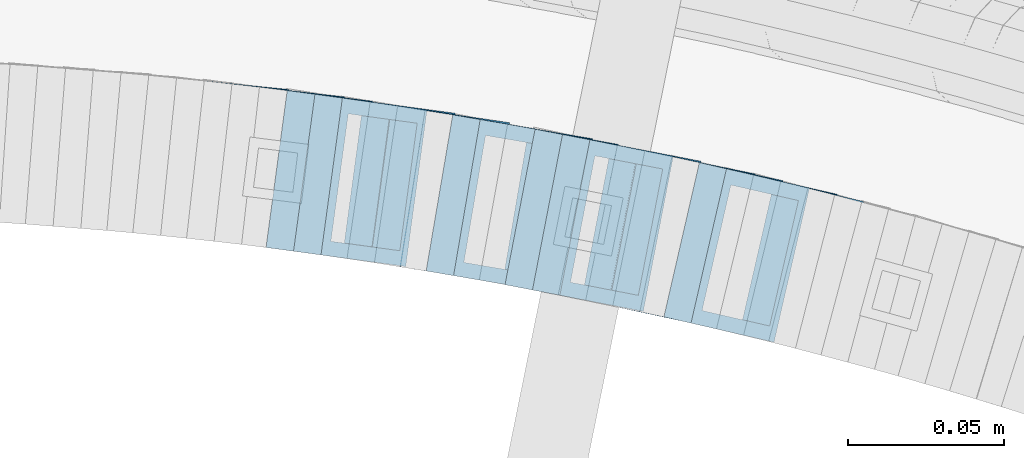
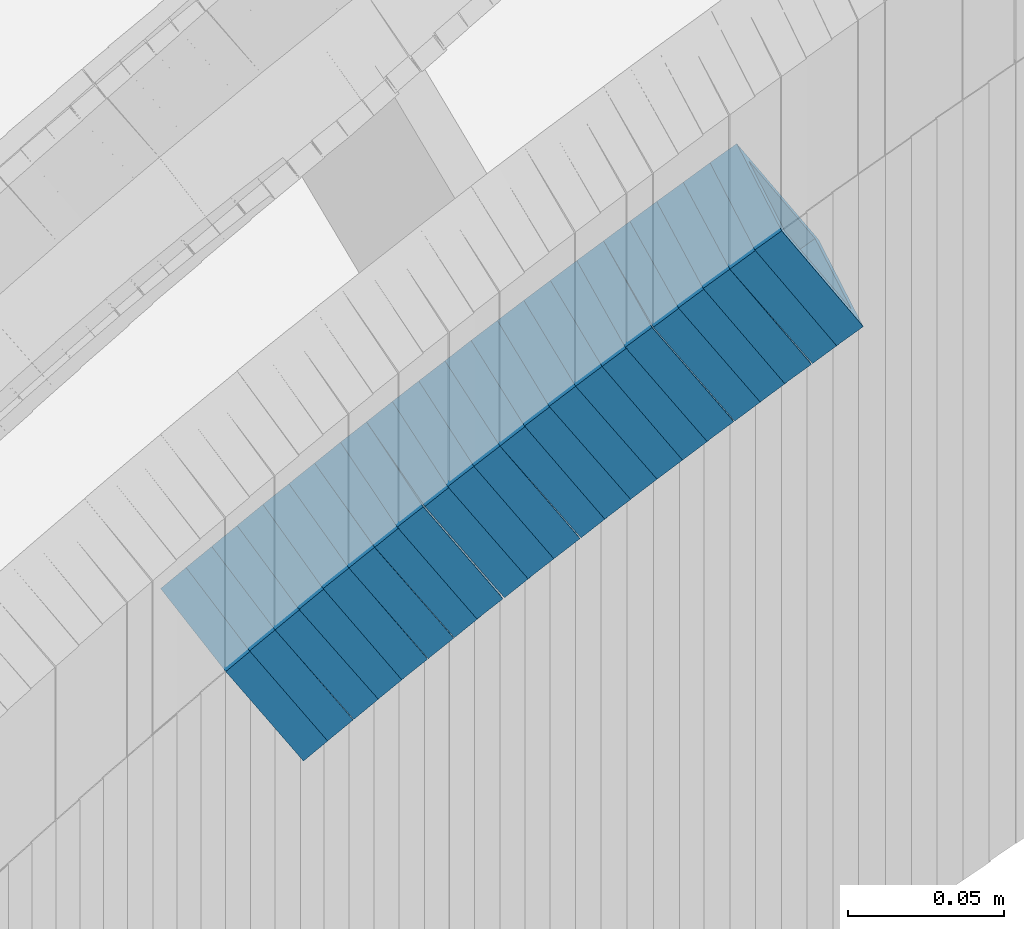
# One storey, part 754 of 975: 22 members.
"""IFC2X3 building model written with IfcOpenShell, lengths in millimetres."""

import ifcopenshell
import ifcopenshell.guid

model = None  # the IFC model being written
_history = None  # IfcOwnerHistory: only IFC2X3 demands one
_inside = {}  # id of a spatial element -> (the spatial element, [elements in it])
_under = {}  # id of a project, library or spatial element -> (it, [spatial elements below it])
_declared = {}  # id of a project -> (the project, [libraries it declares])
_typed = {}  # id of a type object -> (the type object, [elements of that type])
_made_of = {}  # id of a material, layer set ... -> (it, [elements and type objects made of it])


def new_model(schema):
    """Start an empty IFC model of exactly this schema.

    Asked for "IFC4X3", IfcOpenShell would pick the latest addendum, in which some entities
    have other attributes; the version numbers below select the first issue.
    IFC2X3 requires an IfcOwnerHistory on every rooted entity: one is made here for all.
    """
    global model, _history
    if schema == "IFC4X3":
        model = ifcopenshell.file(schema_version=(4, 3, 0, 0))
    else:
        model = ifcopenshell.file(schema=schema)
    _inside.clear()
    _under.clear()
    _declared.clear()
    _typed.clear()
    _made_of.clear()
    _history = None
    if model.schema == "IFC2X3":
        org = make("IfcOrganization", Name="unknown")
        user = make(
            "IfcPersonAndOrganization",
            ThePerson=make("IfcPerson", FamilyName="unknown"),
            TheOrganization=org,
        )
        app = make(
            "IfcApplication",
            ApplicationDeveloper=org,
            Version="unknown",
            ApplicationFullName="unknown",
            ApplicationIdentifier="unknown",
        )
        _history = make(
            "IfcOwnerHistory",
            OwningUser=user,
            OwningApplication=app,
            ChangeAction="ADDED",
            CreationDate=0,
        )
    return model


def make(cls, **values):
    """One entity of the class cls with the attributes given. An attribute that is None is left unset."""
    return model.create_entity(
        cls, **{name: value for name, value in values.items() if value is not None}
    )


def rooted(cls, **values):
    """An entity with a GlobalId (a new one), such as an element, a storey or a relation."""
    return make(cls, GlobalId=ifcopenshell.guid.new(), OwnerHistory=_history, **values)


def si_unit(unit_type, name, prefix=None):
    """IfcSIUnit, for example si_unit("LENGTHUNIT", "METRE", prefix="MILLI")."""
    return make("IfcSIUnit", UnitType=unit_type, Prefix=prefix, Name=name)


def assignment(units):
    """IfcUnitAssignment: the units of a project."""
    return None if units is None else make("IfcUnitAssignment", Units=units)


def point(xyz):
    """IfcCartesianPoint."""
    return None if xyz is None else make("IfcCartesianPoint", Coordinates=xyz)


def direction(xyz):
    """IfcDirection."""
    return None if xyz is None else make("IfcDirection", DirectionRatios=xyz)


def frame(location, z_axis=None, x_axis=None):
    """IfcAxis2Placement3D, a coordinate frame: its origin and axes. An axis left out is left unset."""
    return make(
        "IfcAxis2Placement3D",
        Location=point(location),
        Axis=direction(z_axis),
        RefDirection=direction(x_axis),
    )


def origin_with_axes():
    """The frame at (0, 0, 0) with the z axis (0, 0, 1) and the x axis (1, 0, 0) written out."""
    return frame((0.0, 0.0, 0.0), z_axis=(0.0, 0.0, 1.0), x_axis=(1.0, 0.0, 0.0))


def place(relative_to, where):
    """IfcLocalPlacement: puts the frame where relative to a parent placement (None: the world)."""
    return make(
        "IfcLocalPlacement", PlacementRelTo=relative_to, RelativePlacement=where
    )


def context(
    kind, dimensions, precision=None, world=None, true_north=None, identifier=None
):
    """IfcGeometricRepresentationContext, for example the 3D "Model" context."""
    return make(
        "IfcGeometricRepresentationContext",
        ContextIdentifier=identifier,
        ContextType=kind,
        CoordinateSpaceDimension=dimensions,
        Precision=precision,
        WorldCoordinateSystem=world,
        TrueNorth=true_north,
    )


def subcontext(parent, identifier, kind, view, scale=None):
    """IfcGeometricRepresentationSubContext, for example "Body" below "Model"."""
    return make(
        "IfcGeometricRepresentationSubContext",
        ContextIdentifier=identifier,
        ContextType=kind,
        ParentContext=parent,
        TargetScale=scale,
        TargetView=view,
    )


def project(units=None, contexts=None):
    """IfcProject with its units and contexts."""
    return rooted(
        "IfcProject",
        Name="project",
        RepresentationContexts=contexts,
        UnitsInContext=assignment(units),
    )


def spatial(cls, under=None, at=None, **own):
    """A site, building, storey or space (cls), placed at a placement, below another one or the project."""
    s = rooted(cls, ObjectPlacement=at, **own)
    if under is not None:
        _under.setdefault(under.id(), (under, []))[1].append(s)
    return s


def faces_of(points, faces, orient=None, outer=None):
    """IfcFace entities. A face is a list of loops; a loop is a list of indices into points, from 0.

    orient and outer hold one flag for each loop. By default every Orientation is true, the
    first loop of a face is its IfcFaceOuterBound and the others are IfcFaceBound.
    """
    made = []
    for i, loops in enumerate(faces):
        bounds = []
        for j, loop in enumerate(loops):
            is_outer = j == 0 if outer is None else outer[i][j]
            bounds.append(
                make(
                    "IfcFaceOuterBound" if is_outer else "IfcFaceBound",
                    Bound=make("IfcPolyLoop", Polygon=[points[k] for k in loop]),
                    Orientation=True if orient is None else orient[i][j],
                )
            )
        made.append(make("IfcFace", Bounds=bounds))
    return made


def faceted_brep(points, faces, orient=None, outer=None, voids=None):
    """IfcFacetedBrep: a solid bounded by flat faces; with voids (closed shells), ...WithVoids."""
    shared = [point(p) for p in points]
    hull = make("IfcClosedShell", CfsFaces=faces_of(shared, faces, orient, outer))
    if voids is None:
        return make("IfcFacetedBrep", Outer=hull)
    return make(
        "IfcFacetedBrepWithVoids",
        Outer=hull,
        Voids=[
            make(cls, CfsFaces=faces_of(shared, fs, o, b)) for cls, fs, o, b in voids
        ],
    )


def shape(context_of_items, identifier, shape_type, items):
    """IfcShapeRepresentation: the items that make up one representation, for example the "Body"."""
    return make(
        "IfcShapeRepresentation",
        ContextOfItems=context_of_items,
        RepresentationIdentifier=identifier,
        RepresentationType=shape_type,
        Items=items,
    )


def material(Name=None, Category=None):
    """IfcMaterial."""
    return make("IfcMaterial", Name=Name, Category=Category)


def made_of(thing, what):
    """Note that an element or type object is made of a material, layer set ...; save() writes the relation."""
    if what is not None:
        _made_of.setdefault(what.id(), (what, []))[1].append(thing)
    return thing


def type_object(cls, material=None, **own):
    """A type object (cls), such as IfcWallType, which elements share."""
    return made_of(rooted(cls, **own), material)


def element(
    cls,
    number,
    at=None,
    inside=None,
    cuts=None,
    type_object=None,
    material=None,
    context=None,
    identifier="Body",
    shape_type=None,
    held_by="IfcProductDefinitionShape",
    body=None,
    shapes=None,
    **own,
):
    """One element of the class cls, such as IfcWall. Its Tag is "e" and its number.

    at: its placement. inside: the storey or other place that contains it. cuts: it is an
    opening in that element (IfcRelVoidsElement). A single representation is given by context,
    identifier, shape_type and body (its items); several are given by shapes. held_by: the class
    of the entity that holds the representations. save() writes the other relations.
    """
    e = rooted(cls, Tag="e%d" % number, ObjectPlacement=at, **own)
    if body is not None:
        shapes = [shape(context, identifier, shape_type, body)]
    if shapes is not None:
        e.Representation = make(held_by, Representations=shapes)
    if inside is not None:
        _inside.setdefault(inside.id(), (inside, []))[1].append(e)
    if cuts is not None:
        rooted(
            "IfcRelVoidsElement", RelatingBuildingElement=cuts, RelatedOpeningElement=e
        )
    if type_object is not None:
        _typed.setdefault(type_object.id(), (type_object, []))[1].append(e)
    return made_of(e, material)


def aggregate(whole, parts):
    """IfcRelAggregates: a whole, such as a stair, and the parts it consists of."""
    return rooted("IfcRelAggregates", RelatingObject=whole, RelatedObjects=parts)


def save(model, path):
    """Write the relations noted so far, then the file.

    IfcRelAggregates (storeys below a building ...), IfcRelContainedInSpatialStructure (elements
    in a storey), IfcRelDefinesByType, IfcRelAssociatesMaterial and IfcRelDeclares: one each for
    every whole, place, type object, material and project.
    """
    for whole, parts in _under.values():
        aggregate(whole, parts)
    for where, things in _inside.values():
        rooted(
            "IfcRelContainedInSpatialStructure",
            RelatedElements=things,
            RelatingStructure=where,
        )
    for kind, things in _typed.values():
        rooted("IfcRelDefinesByType", RelatedObjects=things, RelatingType=kind)
    for what, things in _made_of.values():
        rooted("IfcRelAssociatesMaterial", RelatedObjects=things, RelatingMaterial=what)
    for by, libraries in _declared.values():
        rooted("IfcRelDeclares", RelatingContext=by, RelatedDefinitions=libraries)
    model.write(path)


model = new_model("IFC2X3")

# Units and contexts
model_context = context("Model", 3, precision=1e-05, world=origin_with_axes())
body_context = subcontext(model_context, "Body", "Model", "MODEL_VIEW")
ifc_project = project(units=[si_unit("LENGTHUNIT", "METRE", prefix="MILLI"), si_unit("AREAUNIT", "SQUARE_METRE"), si_unit("VOLUMEUNIT", "CUBIC_METRE"), si_unit("MASSUNIT", "GRAM", prefix="KILO"), si_unit("TIMEUNIT", "SECOND"), si_unit("PLANEANGLEUNIT", "RADIAN"), si_unit("SOLIDANGLEUNIT", "STERADIAN"), si_unit("THERMODYNAMICTEMPERATUREUNIT", "DEGREE_CELSIUS"), si_unit("LUMINOUSINTENSITYUNIT", "LUMEN")], contexts=[model_context])

# Site, building, storey
site_placement = place(None, origin_with_axes())
site = spatial("IfcSite", under=ifc_project, at=site_placement, CompositionType="ELEMENT")
building_placement = place(site_placement, origin_with_axes())
building = spatial("IfcBuilding", under=site, at=building_placement, Name="Undefined", CompositionType="ELEMENT")
storey_placement = place(building_placement, origin_with_axes())
storey = spatial("IfcBuildingStorey", under=building, at=storey_placement, Name="Undefined", CompositionType="ELEMENT", Elevation=0.0)

# Members
ifc_material = material()
member_type = type_object("IfcMemberType", Name="HSS2X2X.188_TUBES", PredefinedType="NOTDEFINED")
member_1_placement = place(storey_placement, frame((35069.6793013996, 4759.9651044435, 1257.67602441488), z_axis=(0.234640533210091, 0.972082208547654, -9.88338797469624e-11), x_axis=(0.819915965339808, -0.197910750081933, 0.537186322222464)))
element("IfcMember", 1, at=member_1_placement, inside=storey, type_object=member_type, material=ifc_material, Name="WALL", ObjectType="HSS2X2X.188_TUBES", context=body_context, shape_type="Brep", body=[
    faceted_brep([(0.0, 20.6374999999753, -20.6375000000298), (0.0, -20.6375000000153, -20.6375000000153), (10.6061303028146, -20.6374999999571, -20.6374999999643), (10.6061303027491, 20.6374999999971, -20.6375000000007), (0.0, -20.6374999999825, 20.6375000000335), (10.6061303027855, -20.6374999999825, 20.6375000000116), (0.0, 20.6375000000116, 20.6375000000189), (10.6061303027236, 20.637499999968, 20.6374999999716), (0.0, 25.3999999999724, -25.4000000000342), (0.0, 25.400000000016, 25.4000000000196), (10.6061303027163, 25.3999999999651, 25.3999999999651), (10.6061303027454, 25.3999999999942, -25.4000000000051), (0.0, -25.399999999976, 25.4000000000378), (10.6061303027891, -25.3999999999796, 25.4000000000124), (0.0, -25.400000000016, -25.4000000000196), (10.6061303028182, -25.3999999999505, -25.3999999999542)], [[[0, 1, 2, 3]], [[1, 4, 5, 2]], [[4, 6, 7, 5]], [[6, 0, 3, 7]], [[8, 9, 10, 11]], [[9, 12, 13, 10]], [[12, 14, 15, 13]], [[14, 8, 11, 15]], [[13, 15, 11, 10], [5, 7, 3, 2]], [[14, 12, 9, 8], [6, 4, 1, 0]]]),
])
member_2_placement = place(storey_placement, frame((35044.2613667971, 4766.02646534978, 1240.44756298384), z_axis=(0.211045983876502, 0.977476134076735, -8.82037056726403e-11), x_axis=(0.821712504265714, -0.177415200057454, 0.5415832411753)))
element("IfcMember", 2, at=member_2_placement, inside=storey, type_object=member_type, material=ifc_material, Name="WALL", ObjectType="HSS2X2X.188_TUBES", context=body_context, shape_type="Brep", body=[
    faceted_brep([(0.0, 20.6374999999753, -20.6375000000298), (0.0, -20.6375000000153, -20.6375000000153), (10.7093417165161, -20.637499999968, -20.6374999999534), (10.709341716436, 20.6374999999898, -20.6375000000116), (0.0, -20.6374999999825, 20.6375000000335), (10.7093417164688, -20.6374999999971, 20.6375000000153), (0.0, 20.6375000000116, 20.6375000000189), (10.7093417163924, 20.6374999999643, 20.6374999999571), (0.0, 25.3999999999724, -25.4000000000342), (0.0, 25.400000000016, 25.4000000000196), (10.7093417163815, 25.3999999999542, 25.3999999999469), (10.7093417164288, 25.3999999999869, -25.4000000000196), (0.0, -25.399999999976, 25.4000000000378), (10.7093417164724, -25.3999999999942, 25.4000000000196), (0.0, -25.400000000016, -25.4000000000196), (10.709341716527, -25.3999999999578, -25.3999999999432)], [[[0, 1, 2, 3]], [[1, 4, 5, 2]], [[4, 6, 7, 5]], [[6, 0, 3, 7]], [[8, 9, 10, 11]], [[9, 12, 13, 10]], [[12, 14, 15, 13]], [[14, 8, 11, 15]], [[13, 15, 11, 10], [5, 7, 3, 2]], [[14, 12, 9, 8], [6, 4, 1, 0]]]),
])
member_3_placement = place(storey_placement, frame((35061.4716427701, 4762.00283251687, 1252.00080521363), z_axis=(0.22404129864445, 0.974579651183888, 1.23778590932488e-10), x_axis=(0.817234718278113, -0.187870050063955, 0.544823145185537)))
element("IfcMember", 3, at=member_3_placement, inside=storey, type_object=member_type, material=ifc_material, Name="WALL", ObjectType="HSS2X2X.188_TUBES", context=body_context, shape_type="Brep", body=[
    faceted_brep([(0.0, 20.6374999999753, -20.6375000000298), (0.0, -20.6375000000153, -20.6375000000153), (10.648004507897, -20.6374999999862, -20.637499999968), (10.6480045078188, 20.6374999999771, -20.6375000000808), (0.0, -20.6374999999825, 20.6375000000335), (10.6480045079406, -20.6374999999698, 20.6375000001062), (0.0, 20.6375000000116, 20.6375000000189), (10.6480045078679, 20.6374999999935, 20.6375000000007), (0.0, 25.3999999999724, -25.4000000000342), (0.0, 25.400000000016, 25.4000000000196), (10.6480045078661, 25.3999999999905, 25.4000000000015), (10.648004507806, 25.3999999999705, -25.4000000000997), (0.0, -25.399999999976, 25.4000000000378), (10.6480045079552, -25.3999999999633, 25.4000000001288), (0.0, -25.400000000016, -25.4000000000196), (10.6480045078988, -25.3999999999814, -25.3999999999651)], [[[0, 1, 2, 3]], [[1, 4, 5, 2]], [[4, 6, 7, 5]], [[6, 0, 3, 7]], [[8, 9, 10, 11]], [[9, 12, 13, 10]], [[12, 14, 15, 13]], [[14, 8, 11, 15]], [[13, 15, 11, 10], [5, 7, 3, 2]], [[14, 12, 9, 8], [6, 4, 1, 0]]]),
])
member_4_placement = place(storey_placement, frame((35052.6068766721, 4764.04070978078, 1246.19191049436), z_axis=(0.22404129864445, 0.974579651183888, 1.23778590932488e-10), x_axis=(0.821412929796701, -0.188830558953183, 0.53816709186667)))
element("IfcMember", 4, at=member_4_placement, inside=storey, type_object=member_type, material=ifc_material, Name="WALL", ObjectType="HSS2X2X.188_TUBES", context=body_context, shape_type="Brep", body=[
    faceted_brep([(0.0, 20.6374999999753, -20.6375000000298), (0.0, -20.6375000000153, -20.6375000000153), (10.5948100501191, -20.6375000000335, -20.6375000000844), (10.5948100501555, 20.6374999999971, -20.6375000000116), (0.0, -20.6374999999825, 20.6375000000335), (10.5948100501446, -20.6375000000098, 20.6374999999571), (0.0, 20.6375000000116, 20.6375000000189), (10.5948100501828, 20.6375000000189, 20.6375000000298), (0.0, 25.3999999999724, -25.4000000000342), (0.0, 25.400000000016, 25.4000000000196), (10.5948100501919, 25.4000000000251, 25.4000000000451), (10.5948100501591, 25.3999999999978, -25.4000000000051), (0.0, -25.399999999976, 25.4000000000378), (10.5948100501482, -25.4000000000106, 25.3999999999578), (0.0, -25.400000000016, -25.4000000000196), (10.5948100501118, -25.4000000000378, -25.400000000096)], [[[0, 1, 2, 3]], [[1, 4, 5, 2]], [[4, 6, 7, 5]], [[6, 0, 3, 7]], [[8, 9, 10, 11]], [[9, 12, 13, 10]], [[12, 14, 15, 13]], [[14, 8, 11, 15]], [[13, 15, 11, 10], [5, 7, 3, 2]], [[14, 12, 9, 8], [6, 4, 1, 0]]]),
])
member_5_placement = place(storey_placement, frame((35009.6409990004, 4773.33325378477, 1217.46716838128), z_axis=(0.18967497608257, 0.981846934836625, 7.12652763468214e-11), x_axis=(0.828494490235689, -0.160050072045484, 0.53663847615256)))
element("IfcMember", 5, at=member_5_placement, inside=storey, type_object=member_type, material=ifc_material, Name="WALL", ObjectType="HSS2X2X.188_TUBES", context=body_context, shape_type="Brep", body=[
    faceted_brep([(0.0, 20.6374999999753, -20.6375000000298), (0.0, -20.6375000000153, -20.6375000000153), (10.6216759506497, -20.637499999968, -20.6374999999534), (10.6216759506497, 20.6375000000262, -20.6374999999643), (0.0, -20.6374999999825, 20.6375000000335), (10.6216759506169, -20.6374999999935, 20.637500000008), (0.0, 20.6375000000116, 20.6375000000189), (10.6216759506242, 20.6375000000007, 20.6374999999971), (0.0, 25.3999999999724, -25.4000000000342), (0.0, 25.400000000016, 25.4000000000196), (10.6216759506169, 25.3999999999978, 25.3999999999869), (10.6216759506533, 25.4000000000269, -25.3999999999614), (0.0, -25.399999999976, 25.4000000000378), (10.6216759506242, -25.3999999999942, 25.4000000000051), (0.0, -25.400000000016, -25.4000000000196), (10.6216759506569, -25.3999999999614, -25.3999999999432)], [[[0, 1, 2, 3]], [[1, 4, 5, 2]], [[4, 6, 7, 5]], [[6, 0, 3, 7]], [[8, 9, 10, 11]], [[9, 12, 13, 10]], [[12, 14, 15, 13]], [[14, 8, 11, 15]], [[13, 15, 11, 10], [5, 7, 3, 2]], [[14, 12, 9, 8], [6, 4, 1, 0]]]),
])
member_6_placement = place(storey_placement, frame((35035.7609022619, 4767.905402899, 1234.72169884755), z_axis=(0.202605604136515, 0.979260419486297, 1.52546135723242e-10), x_axis=(0.824209612871647, -0.170526126973412, 0.539999401915797)))
element("IfcMember", 6, at=member_6_placement, inside=storey, type_object=member_type, material=ifc_material, Name="WALL", ObjectType="HSS2X2X.188_TUBES", context=body_context, shape_type="Brep", body=[
    faceted_brep([(0.0, 20.6374999999753, -20.6375000000298), (0.0, -20.6375000000153, -20.6375000000153), (10.5550935571373, -20.6374999999935, -20.6374999999753), (10.5550935571373, 20.6375000000025, -20.6374999999862), (0.0, -20.6374999999825, 20.6375000000335), (10.5550935571027, -20.6374999999989, 20.6374999999862), (0.0, 20.6375000000116, 20.6375000000189), (10.5550935571027, 20.6374999999953, 20.6374999999716), (0.0, 25.3999999999724, -25.4000000000342), (0.0, 25.400000000016, 25.4000000000196), (10.5550935570991, 25.3999999999924, 25.3999999999651), (10.5550935571373, 25.3999999999996, -25.3999999999905), (0.0, -25.399999999976, 25.4000000000378), (10.5550935571009, -25.3999999999996, 25.3999999999833), (0.0, -25.400000000016, -25.4000000000196), (10.5550935571428, -25.3999999999905, -25.3999999999724)], [[[0, 1, 2, 3]], [[1, 4, 5, 2]], [[4, 6, 7, 5]], [[6, 0, 3, 7]], [[8, 9, 10, 11]], [[9, 12, 13, 10]], [[12, 14, 15, 13]], [[14, 8, 11, 15]], [[13, 15, 11, 10], [5, 7, 3, 2]], [[14, 12, 9, 8], [6, 4, 1, 0]]]),
])
member_7_placement = place(storey_placement, frame((35018.4409990004, 4771.63325378477, 1223.16716838128), z_axis=(0.18967497608257, 0.981846934836625, 7.12652763468214e-11), x_axis=(0.828494490235689, -0.160050072045484, 0.53663847615256)))
element("IfcMember", 7, at=member_7_placement, inside=storey, type_object=member_type, material=ifc_material, Name="WALL", ObjectType="HSS2X2X.188_TUBES", context=body_context, shape_type="Brep", body=[
    faceted_brep([(0.0, 20.6374999999753, -20.6375000000298), (0.0, -20.6375000000153, -20.6375000000153), (10.6216759506497, -20.637499999968, -20.6374999999534), (10.6216759506497, 20.6375000000262, -20.6374999999643), (0.0, -20.6374999999825, 20.6375000000335), (10.6216759506169, -20.6374999999935, 20.637500000008), (0.0, 20.6375000000116, 20.6375000000189), (10.6216759506242, 20.6375000000007, 20.6374999999971), (0.0, 25.3999999999724, -25.4000000000342), (0.0, 25.400000000016, 25.4000000000196), (10.6216759506169, 25.3999999999978, 25.3999999999869), (10.6216759506533, 25.4000000000269, -25.3999999999614), (0.0, -25.399999999976, 25.4000000000378), (10.6216759506242, -25.3999999999942, 25.4000000000051), (0.0, -25.400000000016, -25.4000000000196), (10.6216759506569, -25.3999999999614, -25.3999999999432)], [[[0, 1, 2, 3]], [[1, 4, 5, 2]], [[4, 6, 7, 5]], [[6, 0, 3, 7]], [[8, 9, 10, 11]], [[9, 12, 13, 10]], [[12, 14, 15, 13]], [[14, 8, 11, 15]], [[13, 15, 11, 10], [5, 7, 3, 2]], [[14, 12, 9, 8], [6, 4, 1, 0]]]),
])
member_8_placement = place(storey_placement, frame((35026.7613667971, 4769.72646534977, 1228.94756298383), z_axis=(0.211045983876502, 0.977476134076735, -8.82037056726403e-11), x_axis=(0.821712504265714, -0.177415200057454, 0.5415832411753)))
element("IfcMember", 8, at=member_8_placement, inside=storey, type_object=member_type, material=ifc_material, Name="WALL", ObjectType="HSS2X2X.188_TUBES", context=body_context, shape_type="Brep", body=[
    faceted_brep([(0.0, 20.6374999999753, -20.6375000000298), (0.0, -20.6375000000153, -20.6375000000153), (10.7093417165161, -20.637499999968, -20.6374999999534), (10.709341716436, 20.6374999999898, -20.6375000000116), (0.0, -20.6374999999825, 20.6375000000335), (10.7093417164688, -20.6374999999971, 20.6375000000153), (0.0, 20.6375000000116, 20.6375000000189), (10.7093417163924, 20.6374999999643, 20.6374999999571), (0.0, 25.3999999999724, -25.4000000000342), (0.0, 25.400000000016, 25.4000000000196), (10.7093417163815, 25.3999999999542, 25.3999999999469), (10.7093417164288, 25.3999999999869, -25.4000000000196), (0.0, -25.399999999976, 25.4000000000378), (10.7093417164724, -25.3999999999942, 25.4000000000196), (0.0, -25.400000000016, -25.4000000000196), (10.709341716527, -25.3999999999578, -25.3999999999432)], [[[0, 1, 2, 3]], [[1, 4, 5, 2]], [[4, 6, 7, 5]], [[6, 0, 3, 7]], [[8, 9, 10, 11]], [[9, 12, 13, 10]], [[12, 14, 15, 13]], [[14, 8, 11, 15]], [[13, 15, 11, 10], [5, 7, 3, 2]], [[14, 12, 9, 8], [6, 4, 1, 0]]]),
])
member_9_placement = place(storey_placement, frame((34992.3622841126, 4776.72536437467, 1205.97988730625), z_axis=(0.178885438594443, 0.983869910028187, 3.69502458852366e-10), x_axis=(0.829708833093913, -0.150856152017103, 0.537425040060965)))
element("IfcMember", 9, at=member_9_placement, inside=storey, type_object=member_type, material=ifc_material, Name="WALL", ObjectType="HSS2X2X.188_TUBES", context=body_context, shape_type="Brep", body=[
    faceted_brep([(0.0, 20.6374999999753, -20.6375000000298), (0.0, -20.6375000000153, -20.6375000000153), (10.6061303028146, -20.6374999999571, -20.6374999999643), (10.6061303027491, 20.6374999999971, -20.6375000000007), (0.0, -20.6374999999825, 20.6375000000335), (10.6061303027855, -20.6374999999825, 20.6375000000116), (0.0, 20.6375000000116, 20.6375000000189), (10.6061303027236, 20.637499999968, 20.6374999999716), (0.0, 25.3999999999724, -25.4000000000342), (0.0, 25.400000000016, 25.4000000000196), (10.6061303027163, 25.3999999999651, 25.3999999999651), (10.6061303027454, 25.3999999999942, -25.4000000000051), (0.0, -25.399999999976, 25.4000000000378), (10.6061303027891, -25.3999999999796, 25.4000000000124), (0.0, -25.400000000016, -25.4000000000196), (10.6061303028182, -25.3999999999505, -25.3999999999542)], [[[0, 1, 2, 3]], [[1, 4, 5, 2]], [[4, 6, 7, 5]], [[6, 0, 3, 7]], [[8, 9, 10, 11]], [[9, 12, 13, 10]], [[12, 14, 15, 13]], [[14, 8, 11, 15]], [[13, 15, 11, 10], [5, 7, 3, 2]], [[14, 12, 9, 8], [6, 4, 1, 0]]]),
])
member_10_placement = place(storey_placement, frame((35001.0069122114, 4775.001202369, 1211.77557519157), z_axis=(0.18967497608257, 0.981846934836625, 7.12652763468214e-11), x_axis=(0.824303982314706, -0.159240542060768, 0.543291261207384)))
element("IfcMember", 10, at=member_10_placement, inside=storey, type_object=member_type, material=ifc_material, Name="WALL", ObjectType="HSS2X2X.188_TUBES", context=body_context, shape_type="Brep", body=[
    faceted_brep([(0.0, 20.6374999999753, -20.6375000000298), (0.0, -20.6375000000153, -20.6375000000153), (10.6831643251735, -20.6375000000498, -20.6375000000953), (10.6831643252044, 20.637499999988, -20.6375000000226), (0.0, -20.6374999999825, 20.6375000000335), (10.6831643251935, -20.6375000000135, 20.637499999968), (0.0, 20.6375000000116, 20.6375000000189), (10.6831643252244, 20.6375000000226, 20.6375000000407), (0.0, 25.3999999999724, -25.4000000000342), (0.0, 25.400000000016, 25.4000000000196), (10.6831643252317, 25.4000000000306, 25.4000000000597), (10.6831643252044, 25.3999999999905, -25.4000000000196), (0.0, -25.399999999976, 25.4000000000378), (10.6831643251917, -25.400000000016, 25.3999999999614), (0.0, -25.400000000016, -25.4000000000196), (10.6831643251644, -25.400000000056, -25.4000000001179)], [[[0, 1, 2, 3]], [[1, 4, 5, 2]], [[4, 6, 7, 5]], [[6, 0, 3, 7]], [[8, 9, 10, 11]], [[9, 12, 13, 10]], [[12, 14, 15, 13]], [[14, 8, 11, 15]], [[13, 15, 11, 10], [5, 7, 3, 2]], [[14, 12, 9, 8], [6, 4, 1, 0]]]),
])
member_11_placement = place(storey_placement, frame((34975.0826649225, 4779.82180733641, 1194.49191049433), z_axis=(0.168030974253132, 0.98578171604648, 1.54343069880269e-10), x_axis=(0.830854457802148, -0.141622918966304, 0.538167091871811)))
element("IfcMember", 11, at=member_11_placement, inside=storey, type_object=member_type, material=ifc_material, Name="WALL", ObjectType="HSS2X2X.188_TUBES", context=body_context, shape_type="Brep", body=[
    faceted_brep([(0.0, 20.6374999999753, -20.6375000000298), (0.0, -20.6375000000153, -20.6375000000153), (10.5948100501191, -20.6375000000335, -20.6375000000844), (10.5948100501555, 20.6374999999971, -20.6375000000116), (0.0, -20.6374999999825, 20.6375000000335), (10.5948100501446, -20.6375000000098, 20.6374999999571), (0.0, 20.6375000000116, 20.6375000000189), (10.5948100501828, 20.6375000000189, 20.6375000000298), (0.0, 25.3999999999724, -25.4000000000342), (0.0, 25.400000000016, 25.4000000000196), (10.5948100501919, 25.4000000000251, 25.4000000000451), (10.5948100501591, 25.3999999999978, -25.4000000000051), (0.0, -25.399999999976, 25.4000000000378), (10.5948100501482, -25.4000000000106, 25.3999999999578), (0.0, -25.400000000016, -25.4000000000196), (10.5948100501118, -25.4000000000378, -25.400000000096)], [[[0, 1, 2, 3]], [[1, 4, 5, 2]], [[4, 6, 7, 5]], [[6, 0, 3, 7]], [[8, 9, 10, 11]], [[9, 12, 13, 10]], [[12, 14, 15, 13]], [[14, 8, 11, 15]], [[13, 15, 11, 10], [5, 7, 3, 2]], [[14, 12, 9, 8], [6, 4, 1, 0]]]),
])
member_12_placement = place(storey_placement, frame((34984.0493248837, 4778.29339938847, 1200.3008052136), z_axis=(0.168030974253132, 0.98578171604648, 1.54343069880269e-10), x_axis=(0.82662822087749, -0.140902537979205, 0.544823144919464)))
element("IfcMember", 12, at=member_12_placement, inside=storey, type_object=member_type, material=ifc_material, Name="WALL", ObjectType="HSS2X2X.188_TUBES", context=body_context, shape_type="Brep", body=[
    faceted_brep([(0.0, 20.6374999999753, -20.6375000000298), (0.0, -20.6375000000153, -20.6375000000153), (10.648004507897, -20.6374999999862, -20.637499999968), (10.6480045078188, 20.6374999999771, -20.6375000000808), (0.0, -20.6374999999825, 20.6375000000335), (10.6480045079406, -20.6374999999698, 20.6375000001062), (0.0, 20.6375000000116, 20.6375000000189), (10.6480045078679, 20.6374999999935, 20.6375000000007), (0.0, 25.3999999999724, -25.4000000000342), (0.0, 25.400000000016, 25.4000000000196), (10.6480045078661, 25.3999999999905, 25.4000000000015), (10.648004507806, 25.3999999999705, -25.4000000000997), (0.0, -25.399999999976, 25.4000000000378), (10.6480045079552, -25.3999999999633, 25.4000000001288), (0.0, -25.400000000016, -25.4000000000196), (10.6480045078988, -25.3999999999814, -25.3999999999651)], [[[0, 1, 2, 3]], [[1, 4, 5, 2]], [[4, 6, 7, 5]], [[6, 0, 3, 7]], [[8, 9, 10, 11]], [[9, 12, 13, 10]], [[12, 14, 15, 13]], [[14, 8, 11, 15]], [[13, 15, 11, 10], [5, 7, 3, 2]], [[14, 12, 9, 8], [6, 4, 1, 0]]]),
])
member_13_placement = place(storey_placement, frame((34958.0201409783, 4782.82757970332, 1183.01381644291), z_axis=(0.146141233668583, 0.989263736231054, -2.31722651733435e-10), x_axis=(0.832936057838008, -0.123047371976084, 0.539515400895153)))
element("IfcMember", 13, at=member_13_placement, inside=storey, type_object=member_type, material=ifc_material, Name="WALL", ObjectType="HSS2X2X.188_TUBES", context=body_context, shape_type="Brep", body=[
    faceted_brep([(0.0, 20.6374999999753, -20.6375000000298), (0.0, -20.6375000000153, -20.6375000000153), (10.5744976239494, -20.6375000000207, -20.6375000000335), (10.5744976239657, 20.6375000000098, -20.637500000008), (0.0, -20.6374999999825, 20.6375000000335), (10.5744976239639, -20.6375000000244, 20.6374999999753), (0.0, 20.6375000000116, 20.6375000000189), (10.5744976239803, 20.6374999999989, 20.6374999999935), (0.0, 25.3999999999724, -25.4000000000342), (0.0, 25.400000000016, 25.4000000000196), (10.5744976239857, 25.4000000000051, 25.4000000000015), (10.5744976239675, 25.4000000000124, -25.4000000000051), (0.0, -25.399999999976, 25.4000000000378), (10.5744976239639, -25.4000000000287, 25.3999999999724), (0.0, -25.400000000016, -25.4000000000196), (10.5744976239494, -25.4000000000215, -25.4000000000378)], [[[0, 1, 2, 3]], [[1, 4, 5, 2]], [[4, 6, 7, 5]], [[6, 0, 3, 7]], [[8, 9, 10, 11]], [[9, 12, 13, 10]], [[12, 14, 15, 13]], [[14, 8, 11, 15]], [[13, 15, 11, 10], [5, 7, 3, 2]], [[14, 12, 9, 8], [6, 4, 1, 0]]]),
])
member_14_placement = place(storey_placement, frame((34948.9019982794, 4784.12255637274, 1177.30322447156), z_axis=(0.157115048787935, 0.987580306326713, -1.66803829415585e-10), x_axis=(0.831930478100277, -0.132352576016002, 0.538864060065034)))
element("IfcMember", 14, at=member_14_placement, inside=storey, type_object=member_type, material=ifc_material, Name="WALL", ObjectType="HSS2X2X.188_TUBES", context=body_context, shape_type="Brep", body=[
    faceted_brep([(0.0, 20.6374999999753, -20.6375000000298), (0.0, -20.6375000000153, -20.6375000000153), (10.5806427026419, -20.6374999999607, -20.6374999999316), (10.5806427026473, 20.6375000000444, -20.6374999999207), (0.0, -20.6374999999825, 20.6375000000335), (10.5806427025509, -20.6375000000207, 20.6374999999643), (0.0, 20.6375000000116, 20.6375000000189), (10.5806427025545, 20.6374999999862, 20.6374999999716), (0.0, 25.3999999999724, -25.4000000000342), (0.0, 25.400000000016, 25.4000000000196), (10.5806427025436, 25.3999999999796, 25.3999999999614), (10.5806427026582, 25.4000000000542, -25.3999999999105), (0.0, -25.399999999976, 25.4000000000378), (10.5806427025418, -25.4000000000287, 25.3999999999542), (0.0, -25.400000000016, -25.4000000000196), (10.5806427026528, -25.3999999999542, -25.3999999999178)], [[[0, 1, 2, 3]], [[1, 4, 5, 2]], [[4, 6, 7, 5]], [[6, 0, 3, 7]], [[8, 9, 10, 11]], [[9, 12, 13, 10]], [[12, 14, 15, 13]], [[14, 8, 11, 15]], [[13, 15, 11, 10], [5, 7, 3, 2]], [[14, 12, 9, 8], [6, 4, 1, 0]]]),
])
member_15_placement = place(storey_placement, frame((34966.2949228032, 4781.32865058222, 1188.73178438181), z_axis=(0.166195421580291, 0.986092836322093, -3.00360170513159e-10), x_axis=(0.829568675656222, -0.139814944942038, 0.540617788775802)))
element("IfcMember", 15, at=member_15_placement, inside=storey, type_object=member_type, material=ifc_material, Name="WALL", ObjectType="HSS2X2X.188_TUBES", context=body_context, shape_type="Brep", body=[
    faceted_brep([(0.0, 20.6374999999753, -20.6375000000298), (0.0, -20.6375000000153, -20.6375000000153), (10.7284668056709, -20.6374999999935, -20.6374999999971), (10.7284668057473, 20.6375000000553, -20.6374999999907), (0.0, -20.6374999999825, 20.6375000000335), (10.7284668055872, -20.6375000000444, 20.6374999999907), (0.0, 20.6375000000116, 20.6375000000189), (10.7284668056673, 20.6375000000044, 20.6374999999971), (0.0, 25.3999999999724, -25.4000000000342), (0.0, 25.400000000016, 25.4000000000196), (10.7284668056673, 25.4000000000051, 25.3999999999969), (10.7284668057691, 25.4000000000706, -25.3999999999878), (0.0, -25.399999999976, 25.4000000000378), (10.728466805569, -25.4000000000524, 25.3999999999887), (0.0, -25.400000000016, -25.4000000000196), (10.7284668056709, -25.3999999999905, -25.399999999996)], [[[0, 1, 2, 3]], [[1, 4, 5, 2]], [[4, 6, 7, 5]], [[6, 0, 3, 7]], [[8, 9, 10, 11]], [[9, 12, 13, 10]], [[12, 14, 15, 13]], [[14, 8, 11, 15]], [[13, 15, 11, 10], [5, 7, 3, 2]], [[14, 12, 9, 8], [6, 4, 1, 0]]]),
])
member_16_placement = place(storey_placement, frame((34940.7382450837, 4785.54398055301, 1171.56307720517), z_axis=(0.13362233611838, 0.991032326057161, 7.08378138369881e-11), x_axis=(0.832503159066036, -0.112247617008966, 0.542530149043238)))
element("IfcMember", 16, at=member_16_placement, inside=storey, type_object=member_type, material=ifc_material, Name="WALL", ObjectType="HSS2X2X.188_TUBES", context=body_context, shape_type="Brep", body=[
    faceted_brep([(0.0, 20.6374999999753, -20.6375000000298), (0.0, -20.6375000000153, -20.6375000000153), (10.6906501205649, -20.6374999999844, -20.637499999968), (10.690650120574, 20.6375000000098, -20.6374999999716), (0.0, -20.6374999999825, 20.6375000000335), (10.6906501205467, -20.6374999999844, 20.637500000008), (0.0, 20.6375000000116, 20.6375000000189), (10.6906501205558, 20.637500000008, 20.6375000000007), (0.0, 25.3999999999724, -25.4000000000342), (0.0, 25.400000000016, 25.4000000000196), (10.6906501205522, 25.4000000000087, 25.3999999999978), (10.6906501205813, 25.4000000000124, -25.3999999999651), (0.0, -25.399999999976, 25.4000000000378), (10.6906501205431, -25.3999999999833, 25.4000000000051), (0.0, -25.400000000016, -25.4000000000196), (10.6906501205704, -25.3999999999833, -25.3999999999614)], [[[0, 1, 2, 3]], [[1, 4, 5, 2]], [[4, 6, 7, 5]], [[6, 0, 3, 7]], [[8, 9, 10, 11]], [[9, 12, 13, 10]], [[12, 14, 15, 13]], [[14, 8, 11, 15]], [[13, 15, 11, 10], [5, 7, 3, 2]], [[14, 12, 9, 8], [6, 4, 1, 0]]]),
])
member_17_placement = place(storey_placement, frame((34922.8708218354, 4787.96655447412, 1160.05491287783), z_axis=(0.13362233611838, 0.991032326057161, 7.08378138369881e-11), x_axis=(0.836723409209316, -0.112816639028181, 0.535879037133871)))
element("IfcMember", 17, at=member_17_placement, inside=storey, type_object=member_type, material=ifc_material, Name="WALL", ObjectType="HSS2X2X.188_TUBES", context=body_context, shape_type="Brep", body=[
    faceted_brep([(0.0, 20.6374999999753, -20.6375000000298), (0.0, -20.6375000000153, -20.6375000000153), (10.6395488625676, -20.6374999999771, -20.6374999999716), (10.6395488625531, 20.6374999999916, -20.6375000000189), (0.0, -20.6374999999825, 20.6375000000335), (10.6395488625731, -20.6374999999844, 20.6375000000153), (0.0, 20.6375000000116, 20.6375000000189), (10.6395488625585, 20.6374999999825, 20.637499999968), (0.0, 25.3999999999724, -25.4000000000342), (0.0, 25.400000000016, 25.4000000000196), (10.6395488625567, 25.3999999999778, 25.3999999999614), (10.6395488625494, 25.3999999999887, -25.4000000000233), (0.0, -25.399999999976, 25.4000000000378), (10.6395488625749, -25.3999999999851, 25.400000000016), (0.0, -25.400000000016, -25.4000000000196), (10.6395488625658, -25.399999999976, -25.3999999999687)], [[[0, 1, 2, 3]], [[1, 4, 5, 2]], [[4, 6, 7, 5]], [[6, 0, 3, 7]], [[8, 9, 10, 11]], [[9, 12, 13, 10]], [[12, 14, 15, 13]], [[14, 8, 11, 15]], [[13, 15, 11, 10], [5, 7, 3, 2]], [[14, 12, 9, 8], [6, 4, 1, 0]]]),
])
member_18_placement = place(storey_placement, frame((34931.8369500465, 4786.73684005276, 1165.82367432761), z_axis=(0.135113204623682, 0.990830168059249, -2.44440798269352e-10), x_axis=(0.833870408870341, -0.113709600982362, 0.540120604916016)))
element("IfcMember", 18, at=member_18_placement, inside=storey, type_object=member_type, material=ifc_material, Name="WALL", ObjectType="HSS2X2X.188_TUBES", context=body_context, shape_type="Brep", body=[
    faceted_brep([(0.0, 20.6374999999753, -20.6375000000298), (0.0, -20.6375000000153, -20.6375000000153), (10.5531985672587, -20.6374999999916, -20.6375000000007), (10.5531985672878, 20.6375000000062, -20.6374999999789), (0.0, -20.6374999999825, 20.6375000000335), (10.5531985672114, -20.6375000000353, 20.6374999999171), (0.0, 20.6375000000116, 20.6375000000189), (10.5531985672333, 20.6374999999607, 20.6374999999316), (0.0, 25.3999999999724, -25.4000000000342), (0.0, 25.400000000016, 25.4000000000196), (10.5531985672314, 25.399999999956, 25.3999999999251), (10.5531985672933, 25.4000000000106, -25.3999999999724), (0.0, -25.399999999976, 25.4000000000378), (10.5531985672023, -25.4000000000397, 25.3999999999069), (0.0, -25.400000000016, -25.4000000000196), (10.5531985672642, -25.3999999999851, -25.3999999999869)], [[[0, 1, 2, 3]], [[1, 4, 5, 2]], [[4, 6, 7, 5]], [[6, 0, 3, 7]], [[8, 9, 10, 11]], [[9, 12, 13, 10]], [[12, 14, 15, 13]], [[14, 8, 11, 15]], [[13, 15, 11, 10], [5, 7, 3, 2]], [[14, 12, 9, 8], [6, 4, 1, 0]]]),
])
member_19_placement = place(storey_placement, frame((34914.4499302391, 4789.15734074891, 1154.37205230369), z_axis=(0.122662171778764, 0.99244848310354, -1.50217829286703e-10), x_axis=(0.833342100544206, -0.102997337943623, 0.543076874702926)))
element("IfcMember", 19, at=member_19_placement, inside=storey, type_object=member_type, material=ifc_material, Name="WALL", ObjectType="HSS2X2X.188_TUBES", context=body_context, shape_type="Brep", body=[
    faceted_brep([(0.0, 20.6374999999753, -20.6375000000298), (0.0, -20.6375000000153, -20.6375000000153), (10.6831643251735, -20.6375000000498, -20.6375000000953), (10.6831643252044, 20.637499999988, -20.6375000000226), (0.0, -20.6374999999825, 20.6375000000335), (10.6831643251935, -20.6375000000135, 20.637499999968), (0.0, 20.6375000000116, 20.6375000000189), (10.6831643252244, 20.6375000000226, 20.6375000000407), (0.0, 25.3999999999724, -25.4000000000342), (0.0, 25.400000000016, 25.4000000000196), (10.6831643252317, 25.4000000000306, 25.4000000000597), (10.6831643252044, 25.3999999999905, -25.4000000000196), (0.0, -25.399999999976, 25.4000000000378), (10.6831643251917, -25.400000000016, 25.3999999999614), (0.0, -25.400000000016, -25.4000000000196), (10.6831643251644, -25.400000000056, -25.4000000001179)], [[[0, 1, 2, 3]], [[1, 4, 5, 2]], [[4, 6, 7, 5]], [[6, 0, 3, 7]], [[8, 9, 10, 11]], [[9, 12, 13, 10]], [[12, 14, 15, 13]], [[14, 8, 11, 15]], [[13, 15, 11, 10], [5, 7, 3, 2]], [[14, 12, 9, 8], [6, 4, 1, 0]]]),
])
member_20_placement = place(storey_placement, frame((34905.8659983127, 4790.2678952849, 1148.64114328663), z_axis=(0.112909687892483, 0.993605254806969, -5.47270246897824e-11), x_axis=(0.835522531012285, -0.0949457420013783, 0.541190730008037)))
element("IfcMember", 20, at=member_20_placement, inside=storey, type_object=member_type, material=ifc_material, Name="WALL", ObjectType="HSS2X2X.188_TUBES", context=body_context, shape_type="Brep", body=[
    faceted_brep([(0.0, 20.6374999999753, -20.6375000000298), (0.0, -20.6375000000153, -20.6375000000153), (10.5290075505945, -20.637499999968, -20.6375000000116), (10.5290075505436, 20.6374999999898, -20.637499999998), (0.0, -20.6374999999825, 20.6375000000335), (10.5290075505145, -20.6375000000189, 20.637500000008), (0.0, 20.6375000000116, 20.6375000000189), (10.5290075504672, 20.6374999999462, 20.6375000000198), (0.0, 25.3999999999724, -25.4000000000342), (0.0, 25.400000000016, 25.4000000000196), (10.5290075504563, 25.399999999936, 25.4000000000224), (10.5290075505472, 25.3999999999869, -25.3999999999987), (0.0, -25.399999999976, 25.4000000000378), (10.5290075505072, -25.4000000000196, 25.4000000000106), (0.0, -25.400000000016, -25.4000000000196), (10.5290075506091, -25.3999999999651, -25.4000000000151)], [[[0, 1, 2, 3]], [[1, 4, 5, 2]], [[4, 6, 7, 5]], [[6, 0, 3, 7]], [[8, 9, 10, 11]], [[9, 12, 13, 10]], [[12, 14, 15, 13]], [[14, 8, 11, 15]], [[13, 15, 11, 10], [5, 7, 3, 2]], [[14, 12, 9, 8], [6, 4, 1, 0]]]),
])
member_21_placement = place(storey_placement, frame((34896.8920691227, 4791.29362077117, 1142.87178395397), z_axis=(0.111656944986629, 0.993746812138913, 9.1649781097658e-12), x_axis=(0.838355173155823, -0.0941972100175166, 0.536924100099619)))
element("IfcMember", 21, at=member_21_placement, inside=storey, type_object=member_type, material=ifc_material, Name="WALL", ObjectType="HSS2X2X.188_TUBES", context=body_context, shape_type="Brep", body=[
    faceted_brep([(0.0, 20.6374999999753, -20.6375000000298), (0.0, -20.6375000000153, -20.6375000000153), (10.6216759506497, -20.637499999968, -20.6374999999534), (10.6216759506497, 20.6375000000262, -20.6374999999643), (0.0, -20.6374999999825, 20.6375000000335), (10.6216759506169, -20.6374999999935, 20.637500000008), (0.0, 20.6375000000116, 20.6375000000189), (10.6216759506242, 20.6375000000007, 20.6374999999971), (0.0, 25.3999999999724, -25.4000000000342), (0.0, 25.400000000016, 25.4000000000196), (10.6216759506169, 25.3999999999978, 25.3999999999869), (10.6216759506533, 25.4000000000269, -25.3999999999614), (0.0, -25.399999999976, 25.4000000000378), (10.6216759506242, -25.3999999999942, 25.4000000000051), (0.0, -25.400000000016, -25.4000000000196), (10.6216759506569, -25.3999999999614, -25.3999999999432)], [[[0, 1, 2, 3]], [[1, 4, 5, 2]], [[4, 6, 7, 5]], [[6, 0, 3, 7]], [[8, 9, 10, 11]], [[9, 12, 13, 10]], [[12, 14, 15, 13]], [[14, 8, 11, 15]], [[13, 15, 11, 10], [5, 7, 3, 2]], [[14, 12, 9, 8], [6, 4, 1, 0]]]),
])
member_22_placement = place(storey_placement, frame((34888.3001815299, 4792.31316429257, 1137.1791141229), z_axis=(0.100610483547032, 0.994925892014291, 3.45884473063052e-10), x_axis=(0.839062756003389, -0.0848490430003429, 0.53737727100234)))
element("IfcMember", 22, at=member_22_placement, inside=storey, type_object=member_type, material=ifc_material, Name="WALL", ObjectType="HSS2X2X.188_TUBES", context=body_context, shape_type="Brep", body=[
    faceted_brep([(0.0, 20.6374999999753, -20.6375000000298), (0.0, -20.6375000000153, -20.6375000000153), (10.6061303028146, -20.6374999999571, -20.6374999999643), (10.6061303027491, 20.6374999999971, -20.6375000000007), (0.0, -20.6374999999825, 20.6375000000335), (10.6061303027855, -20.6374999999825, 20.6375000000116), (0.0, 20.6375000000116, 20.6375000000189), (10.6061303027236, 20.637499999968, 20.6374999999716), (0.0, 25.3999999999724, -25.4000000000342), (0.0, 25.400000000016, 25.4000000000196), (10.6061303027163, 25.3999999999651, 25.3999999999651), (10.6061303027454, 25.3999999999942, -25.4000000000051), (0.0, -25.399999999976, 25.4000000000378), (10.6061303027891, -25.3999999999796, 25.4000000000124), (0.0, -25.400000000016, -25.4000000000196), (10.6061303028182, -25.3999999999505, -25.3999999999542)], [[[0, 1, 2, 3]], [[1, 4, 5, 2]], [[4, 6, 7, 5]], [[6, 0, 3, 7]], [[8, 9, 10, 11]], [[9, 12, 13, 10]], [[12, 14, 15, 13]], [[14, 8, 11, 15]], [[13, 15, 11, 10], [5, 7, 3, 2]], [[14, 12, 9, 8], [6, 4, 1, 0]]]),
])

save(model, "model.ifc")
